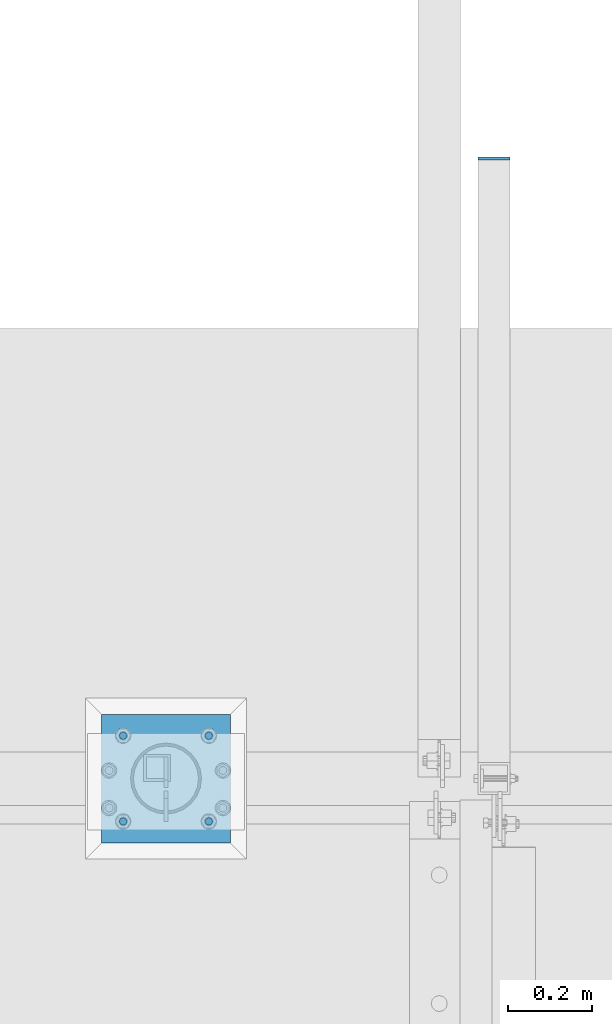
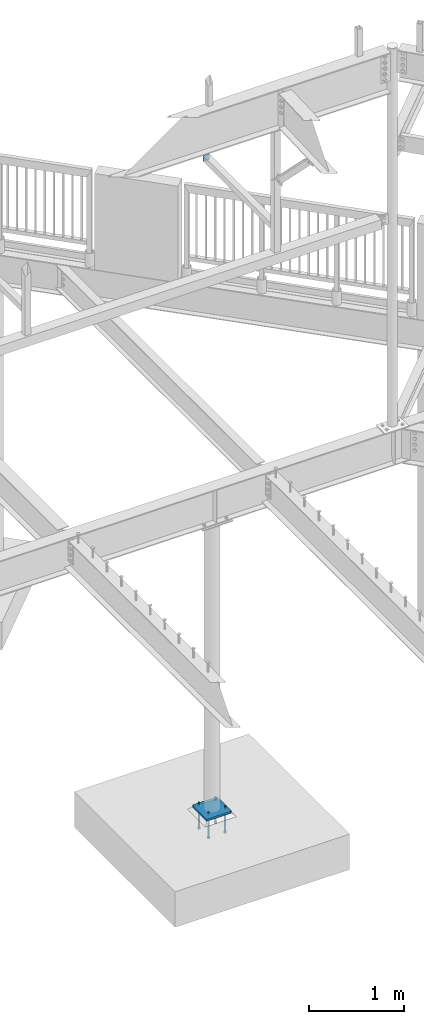
# One storey, part 447 of 975: 7 beams.
"""IFC2X3 building model written with IfcOpenShell, lengths in millimetres."""

from ifc_helpers import new_model, si_unit, frame, origin_with_axes, place, context, subcontext, project, spatial, faceted_brep, material, type_object, element, save


model = new_model("IFC2X3")

# Units and contexts
model_context = context("Model", 3, precision=1e-05, world=origin_with_axes())
body_context = subcontext(model_context, "Body", "Model", "MODEL_VIEW")
ifc_project = project(units=[si_unit("LENGTHUNIT", "METRE", prefix="MILLI"), si_unit("AREAUNIT", "SQUARE_METRE"), si_unit("VOLUMEUNIT", "CUBIC_METRE"), si_unit("MASSUNIT", "GRAM", prefix="KILO"), si_unit("TIMEUNIT", "SECOND"), si_unit("PLANEANGLEUNIT", "RADIAN"), si_unit("SOLIDANGLEUNIT", "STERADIAN"), si_unit("THERMODYNAMICTEMPERATUREUNIT", "DEGREE_CELSIUS"), si_unit("LUMINOUSINTENSITYUNIT", "LUMEN")], contexts=[model_context])

# Site, building, storey
site_placement = place(None, origin_with_axes())
site = spatial("IfcSite", under=ifc_project, at=site_placement, CompositionType="ELEMENT")
building_placement = place(site_placement, origin_with_axes())
building = spatial("IfcBuilding", under=site, at=building_placement, Name="Undefined", CompositionType="ELEMENT")
storey_placement = place(building_placement, origin_with_axes())
storey = spatial("IfcBuildingStorey", under=building, at=storey_placement, Name="Undefined", CompositionType="ELEMENT", Elevation=0.0)

# Beams
ifc_material_1 = material(Name="STEEL/A36")
beam_type_1 = type_object("IfcBeamType", PredefinedType="NOTDEFINED")
beam_1_placement = place(storey_placement, frame((23701.375, 22117.0499996575, 7035.8), z_axis=(1.0, 0.0, 0.0), x_axis=(0.0, 0.0, -1.0)))
element("IfcBeam", 1, at=beam_1_placement, inside=storey, type_object=beam_type_1, material=ifc_material_1, Name="PLATE", context=body_context, shape_type="Brep", body=[
    faceted_brep([(0.0, 3.17500000000018, -38.1000000000004), (0.0, 3.17500000000018, 38.1000000000004), (76.2000000000007, 3.17500000000018, 38.1000000000004), (76.2000000000007, 3.17500000000018, -38.1000000000004), (0.0, -3.17500000000018, 38.1000000000004), (76.2000000000007, -3.17500000000018, 38.1000000000004), (0.0, -3.17500000000018, -38.1000000000004), (76.2000000000007, -3.17500000000018, -38.1000000000004)], [[[0, 1, 2, 3]], [[1, 4, 5, 2]], [[4, 6, 7, 5]], [[6, 0, 3, 7]], [[5, 7, 3, 2]], [[6, 4, 1, 0]]]),
])
ifc_material_2 = material(Name="STEEL/F1554-36")
beam_type_2 = type_object("IfcBeamType", PredefinedType="NOTDEFINED")
beam_2_placement = place(storey_placement, frame((23025.0999984741, 20748.625, -304.799999999999), z_axis=(0.0, 1.0, 0.0), x_axis=(0.0, 0.0, -1.0)))
element("IfcBeam", 2, at=beam_2_placement, inside=storey, type_object=beam_type_2, material=ifc_material_2, Name="HEADED_ANCHOR_BOLT", context=body_context, shape_type="Brep", body=[
    faceted_brep([(209.543749999999, -9.13000011446275, 15.8100004196049), (209.543749999999, -18.2600002288382, 4.72937244921923e-11), (228.593749999998, -18.2600002288382, 4.72937244921923e-11), (228.593749999998, -9.13000011446275, 15.8100004196049), (209.543749999999, 9.13000011438271, 15.8100004195576), (228.593749999998, 9.13000011438271, 15.8100004195576), (209.543749999999, 18.2600002288382, -4.72937244921923e-11), (228.593749999998, 18.2600002288382, -4.72937244921923e-11), (209.543749999999, 9.13000011446275, -15.8100004196049), (228.593749999998, 9.13000011446275, -15.8100004196049), (209.543749999999, -9.13000011438271, -15.8100004195576), (228.593749999998, -9.13000011438271, -15.8100004195576), (209.543749999999, -4.4776800552936, 9.29799844178979), (209.543749999999, -8.068500660469, 6.43441456491473), (209.543749999999, -10.0612557561763, 2.2964159705416), (209.543749999999, -10.0612557561617, -2.29641597048976), (209.543749999999, -8.0685006604399, -6.4344145648729), (209.543749999999, -4.47768005524995, -9.29799844176705), (209.543749999999, 2.91038304567337e-11, -10.3199996948015), (209.543749999999, 4.4776800552936, -9.29799844178979), (209.543749999999, 8.068500660469, -6.43441456491473), (209.543749999999, 10.0612557561763, -2.2964159705416), (209.543749999999, 10.0612557561617, 2.29641597048976), (209.543749999999, 8.0685006604399, 6.4344145648729), (209.543749999999, 4.47768005524995, 9.29799844176705), (209.543749999999, -2.91038304567337e-11, 10.3199996948015), (228.593749999998, -2.91038304567337e-11, 10.3199996948015), (228.593749999998, -4.4776800552936, 9.29799844178979), (228.593749999998, -8.068500660469, 6.43441456491473), (228.593749999998, -10.0612557561763, 2.2964159705416), (228.593749999998, -10.0612557561617, -2.29641597048976), (228.593749999998, -8.0685006604399, -6.4344145648729), (228.593749999998, -4.47768005524995, -9.29799844176705), (228.593749999998, 2.91038304567337e-11, -10.3199996948015), (228.593749999998, 4.4776800552936, -9.29799844178979), (228.593749999998, 8.068500660469, -6.43441456491473), (228.593749999998, 10.0612557561763, -2.2964159705416), (228.593749999998, 10.0612557561617, 2.29641597048976), (228.593749999998, 8.0685006604399, 6.4344145648729), (228.593749999998, 4.47768005524995, 9.29799844176705), (0.0, -6.73519209080223, 6.73519209080186), (0.0, -9.52499999999964, 0.0), (228.6, -9.52500000000146, 0.0), (228.6, -6.73519209080405, 6.73519209080223), (-9.87109982941227e-13, -1.20792265079217e-13, 9.52499961853027), (228.6, 0.0, 9.52499999999964), (0.0, 6.73519209080223, 6.73519209080186), (228.6, 6.73519209080405, 6.73519209080223), (0.0, 9.52499999999964, 0.0), (228.6, 9.52500000000146, 0.0), (0.0, 6.73519209080223, -6.73519209080186), (228.6, 6.73519209080405, -6.73519209080223), (2.95075507493764e-12, -1.20792265079217e-13, -9.52499961853027), (228.6, 0.0, -9.52499999999964), (-114.297914995421, -6.36396103067818, 6.36396103068091), (-114.297914995421, -2.18278728425503e-11, 8.99999999997999), (-114.297914995421, 6.36396103064908, 6.36396103064817), (-114.297914995421, 8.99999999997817, -2.27373675443232e-11), (-114.297914995421, 6.36396103067818, -6.36396103068091), (-114.297914995421, 2.18278728425503e-11, -8.99999999997999), (-114.297914995421, -6.36396103064908, -6.36396103064817), (-114.297914995421, -8.99999999997817, 2.27373675443232e-11), (0.0149743263646087, 6.36396103067818, -6.36396103067909), (0.0149743263646087, 0.0, -9.0), (0.0149743263646087, -6.36396103067818, -6.36396103067909), (0.0149743263987148, -8.9999995411581, -1.00796984270346e-06), (0.0149743263646087, -6.36396103067818, 6.36396103067909), (0.0149743263646087, 0.0, 9.0), (0.0149743263646087, 6.36396103067818, 6.36396103067909), (0.0149743263987148, 9.0000004588419, -1.00796984270346e-06), (0.0, -6.73519209080223, -6.73519209080186), (228.6, -6.73519209080405, -6.73519209080223)], [[[0, 1, 2, 3]], [[4, 0, 3, 5]], [[6, 4, 5, 7]], [[8, 6, 7, 9]], [[10, 8, 9, 11]], [[0, 4, 6, 8, 10, 1], [12, 13, 14, 15, 16, 17, 18, 19, 20, 21, 22, 23, 24, 25]], [[12, 25, 26, 27]], [[13, 12, 27, 28]], [[14, 13, 28, 29]], [[15, 14, 29, 30]], [[16, 15, 30, 31]], [[17, 16, 31, 32]], [[18, 17, 32, 33]], [[19, 18, 33, 34]], [[20, 19, 34, 35]], [[21, 20, 35, 36]], [[22, 21, 36, 37]], [[23, 22, 37, 38]], [[24, 23, 38, 39]], [[25, 24, 39, 26]], [[9, 7, 5, 3, 2, 11], [38, 37, 36, 35, 34, 33, 32, 31, 30, 29, 28, 27, 26, 39]], [[1, 10, 11, 2]], [[40, 41, 42, 43]], [[44, 40, 43, 45]], [[46, 44, 45, 47]], [[48, 46, 47, 49]], [[50, 48, 49, 51]], [[52, 50, 51, 53]], [[54, 55, 56, 57, 58, 59, 60, 61]], [[59, 58, 62, 63]], [[60, 59, 63, 64]], [[61, 60, 64, 65]], [[54, 61, 65, 66]], [[55, 54, 66, 67]], [[56, 55, 67, 68]], [[57, 56, 68, 69]], [[58, 57, 69, 62]], [[40, 44, 46, 48, 50, 52, 70, 41], [68, 67, 66, 65, 64, 63, 62, 69]], [[41, 70, 71, 42]], [[53, 51, 49, 47, 45, 43, 42, 71]], [[70, 52, 53, 71]]]),
])
beam_3_placement = place(storey_placement, frame((22821.9139610307, 20748.6110389745, -304.799999999999), z_axis=(0.0, -1.0, 0.0), x_axis=(0.0, 0.0, -1.0)))
element("IfcBeam", 3, at=beam_3_placement, inside=storey, type_object=beam_type_2, material=ifc_material_2, Name="HEADED_ANCHOR_BOLT", context=body_context, shape_type="Brep", body=[
    faceted_brep([(209.543749999997, -9.14395961924311, 15.7960393889371), (209.543749999997, -18.273959733684, -0.0139610306796385), (228.593749999996, -18.273959733684, -0.0139610306796385), (228.593749999996, -9.14395961924311, 15.7960393889371), (209.543749999997, 9.11604060963873, 15.7960393889371), (228.593749999996, 9.11604060963873, 15.7960393889371), (209.543749999997, 18.2460407240796, -0.0139610306796385), (228.593749999996, 18.2460407240796, -0.0139610306796385), (209.543749999997, 9.11604060963873, -15.8239614502963), (228.593749999996, 9.11604060963873, -15.8239614502963), (209.543749999997, -9.14395961924311, -15.8239614502963), (228.593749999996, -9.14395961924311, -15.8239614502963), (209.543749999997, -4.49163956008488, 9.28403741111924), (209.543749999997, -8.08246016527482, 6.42045353422873), (209.543749999997, -10.075215260993, 2.28245493984195), (209.543749999997, -10.075215260993, -2.31037700120123), (209.543749999997, -8.08246016527482, -6.448375595588), (209.543749999997, -4.49163956008488, -9.31195947247852), (209.543749999997, -0.0139595048021874, -10.3339607255039), (209.543749999997, 4.4637205504805, -9.31195947247852), (209.543749999997, 8.05454115567045, -6.448375595588), (209.543749999997, 10.0472962513886, -2.31037700120123), (209.543749999997, 10.0472962513886, 2.28245493984195), (209.543749999997, 8.05454115567045, 6.42045353422873), (209.543749999997, 4.4637205504805, 9.28403741111924), (209.543749999997, -0.0139595048021874, 10.3060386641446), (228.593749999996, -0.0139595048021874, 10.3060386641446), (228.593749999996, -4.49163956008488, 9.28403741111924), (228.593749999996, -8.08246016527482, 6.42045353422873), (228.593749999996, -10.075215260993, 2.28245493984195), (228.593749999996, -10.075215260993, -2.31037700120123), (228.593749999996, -8.08246016527482, -6.448375595588), (228.593749999996, -4.49163956008488, -9.31195947247852), (228.593749999996, -0.0139595048021874, -10.3339607255039), (228.593749999996, 4.4637205504805, -9.31195947247852), (228.593749999996, 8.05454115567045, -6.448375595588), (228.593749999996, 10.0472962513886, -2.31037700120123), (228.593749999996, 10.0472962513886, 2.28245493984195), (228.593749999996, 8.05454115567045, 6.42045353422873), (228.593749999996, 4.4637205504805, 9.28403741111924), (0.0, -6.73519209080223, 6.73519209080186), (0.0, -9.52499999999964, 0.0), (228.6, -9.52500000000146, 0.0), (228.6, -6.73519209080405, 6.73519209080223), (-9.87109982941227e-13, -1.20792265079217e-13, 9.52499961853027), (228.6, 0.0, 9.52499999999964), (0.0, 6.73519209080223, 6.73519209080186), (228.6, 6.73519209080405, 6.73519209080223), (0.0, 9.52499999999964, 0.0), (228.6, 9.52500000000146, 0.0), (0.0, 6.73519209080223, -6.73519209080186), (228.6, 6.73519209080405, -6.73519209080223), (2.95075507493764e-12, -1.20792265079217e-13, -9.52499961853027), (228.6, 0.0, -9.52499999999964), (-114.299999999999, -6.37792053548037, 6.34999999999945), (-114.299999999999, -0.0139595048021874, 8.98603896932036), (-114.299999999999, 6.350001525876, 6.34999999999945), (-114.299999999999, 8.98604049519781, -0.0139610306796385), (-114.299999999999, 6.350001525876, -6.37792206135873), (-114.299999999999, -0.0139595048021874, -9.01396103067964), (-114.299999999999, -6.37792053548037, -6.37792206135873), (-114.299999999999, -9.01395950480219, -0.0139610306796385), (0.00625000636608775, 6.350001525876, -6.37792205092774), (0.00625000900208761, -0.0139595048021874, -9.01396102024955), (0.00625000636608775, -6.37792053548037, -6.37792205092774), (0.00625000000218279, -9.01395950480219, -0.0139610202495533), (0.00624999363827783, -6.37792053548037, 6.35000001042863), (0.00624999100227797, -0.0139595048021874, 8.98603897975045), (0.00624999363827783, 6.350001525876, 6.35000001042863), (0.00625000000218279, 8.98604049519781, -0.0139610202495533), (0.0, -6.73519209080223, -6.73519209080186), (228.6, -6.73519209080405, -6.73519209080223)], [[[0, 1, 2, 3]], [[4, 0, 3, 5]], [[6, 4, 5, 7]], [[8, 6, 7, 9]], [[10, 8, 9, 11]], [[0, 4, 6, 8, 10, 1], [12, 13, 14, 15, 16, 17, 18, 19, 20, 21, 22, 23, 24, 25]], [[12, 25, 26, 27]], [[13, 12, 27, 28]], [[14, 13, 28, 29]], [[15, 14, 29, 30]], [[16, 15, 30, 31]], [[17, 16, 31, 32]], [[18, 17, 32, 33]], [[19, 18, 33, 34]], [[20, 19, 34, 35]], [[21, 20, 35, 36]], [[22, 21, 36, 37]], [[23, 22, 37, 38]], [[24, 23, 38, 39]], [[25, 24, 39, 26]], [[9, 7, 5, 3, 2, 11], [38, 37, 36, 35, 34, 33, 32, 31, 30, 29, 28, 27, 26, 39]], [[1, 10, 11, 2]], [[40, 41, 42, 43]], [[44, 40, 43, 45]], [[46, 44, 45, 47]], [[48, 46, 47, 49]], [[50, 48, 49, 51]], [[52, 50, 51, 53]], [[54, 55, 56, 57, 58, 59, 60, 61]], [[59, 58, 62, 63]], [[60, 59, 63, 64]], [[61, 60, 64, 65]], [[54, 61, 65, 66]], [[55, 54, 66, 67]], [[56, 55, 67, 68]], [[57, 56, 68, 69]], [[58, 57, 69, 62]], [[40, 44, 46, 48, 50, 52, 70, 41], [68, 67, 66, 65, 64, 63, 62, 69]], [[41, 70, 71, 42]], [[53, 51, 49, 47, 45, 43, 42, 71]], [[70, 52, 53, 71]]]),
])
beam_4_placement = place(storey_placement, frame((22821.9000015259, 20545.4250030518, -304.799999999999), z_axis=(0.0, -1.0, 0.0), x_axis=(0.0, 0.0, -1.0)))
element("IfcBeam", 4, at=beam_4_placement, inside=storey, type_object=beam_type_2, material=ifc_material_2, Name="HEADED_ANCHOR_BOLT", context=body_context, shape_type="Brep", body=[
    faceted_brep([(209.543749999999, -9.13000011446275, 15.8100004196049), (209.543749999999, -18.2600002288382, 4.72937244921923e-11), (228.593749999998, -18.2600002288382, 4.72937244921923e-11), (228.593749999998, -9.13000011446275, 15.8100004196049), (209.543749999999, 9.13000011438271, 15.8100004195576), (228.593749999998, 9.13000011438271, 15.8100004195576), (209.543749999999, 18.2600002288382, -4.72937244921923e-11), (228.593749999998, 18.2600002288382, -4.72937244921923e-11), (209.543749999999, 9.13000011446275, -15.8100004196049), (228.593749999998, 9.13000011446275, -15.8100004196049), (209.543749999999, -9.13000011438271, -15.8100004195576), (228.593749999998, -9.13000011438271, -15.8100004195576), (209.543749999999, -4.4776800552936, 9.29799844178979), (209.543749999999, -8.068500660469, 6.43441456491473), (209.543749999999, -10.0612557561763, 2.2964159705416), (209.543749999999, -10.0612557561617, -2.29641597048976), (209.543749999999, -8.0685006604399, -6.4344145648729), (209.543749999999, -4.47768005524995, -9.29799844176705), (209.543749999999, 2.91038304567337e-11, -10.3199996948015), (209.543749999999, 4.4776800552936, -9.29799844178979), (209.543749999999, 8.068500660469, -6.43441456491473), (209.543749999999, 10.0612557561763, -2.2964159705416), (209.543749999999, 10.0612557561617, 2.29641597048976), (209.543749999999, 8.0685006604399, 6.4344145648729), (209.543749999999, 4.47768005524995, 9.29799844176705), (209.543749999999, -2.91038304567337e-11, 10.3199996948015), (228.593749999998, -2.91038304567337e-11, 10.3199996948015), (228.593749999998, -4.4776800552936, 9.29799844178979), (228.593749999998, -8.068500660469, 6.43441456491473), (228.593749999998, -10.0612557561763, 2.2964159705416), (228.593749999998, -10.0612557561617, -2.29641597048976), (228.593749999998, -8.0685006604399, -6.4344145648729), (228.593749999998, -4.47768005524995, -9.29799844176705), (228.593749999998, 2.91038304567337e-11, -10.3199996948015), (228.593749999998, 4.4776800552936, -9.29799844178979), (228.593749999998, 8.068500660469, -6.43441456491473), (228.593749999998, 10.0612557561763, -2.2964159705416), (228.593749999998, 10.0612557561617, 2.29641597048976), (228.593749999998, 8.0685006604399, 6.4344145648729), (228.593749999998, 4.47768005524995, 9.29799844176705), (0.0, -6.73519209080223, 6.73519209080186), (0.0, -9.52499999999964, 0.0), (228.6, -9.52500000000146, 0.0), (228.6, -6.73519209080405, 6.73519209080223), (-9.87109982941227e-13, -1.20792265079217e-13, 9.52499961853027), (228.6, 0.0, 9.52499999999964), (0.0, 6.73519209080223, 6.73519209080186), (228.6, 6.73519209080405, 6.73519209080223), (0.0, 9.52499999999964, 0.0), (228.6, 9.52500000000146, 0.0), (0.0, 6.73519209080223, -6.73519209080186), (228.6, 6.73519209080405, -6.73519209080223), (2.95075507493764e-12, -1.20792265079217e-13, -9.52499961853027), (228.6, 0.0, -9.52499999999964), (-114.297914995421, -6.36396103067818, 6.36396103068091), (-114.297914995421, -2.18278728425503e-11, 8.99999999997999), (-114.297914995421, 6.36396103064908, 6.36396103064817), (-114.297914995421, 8.99999999997817, -2.27373675443232e-11), (-114.297914995421, 6.36396103067818, -6.36396103068091), (-114.297914995421, 2.18278728425503e-11, -8.99999999997999), (-114.297914995421, -6.36396103064908, -6.36396103064817), (-114.297914995421, -8.99999999997817, 2.27373675443232e-11), (0.0149743263646087, 6.36396103067818, -6.36396103067909), (0.0149743263646087, 0.0, -9.0), (0.0149743263646087, -6.36396103067818, -6.36396103067909), (0.0149743263987148, -8.9999995411581, -1.00796984270346e-06), (0.0149743263646087, -6.36396103067818, 6.36396103067909), (0.0149743263646087, 0.0, 9.0), (0.0149743263646087, 6.36396103067818, 6.36396103067909), (0.0149743263987148, 9.0000004588419, -1.00796984270346e-06), (0.0, -6.73519209080223, -6.73519209080186), (228.6, -6.73519209080405, -6.73519209080223)], [[[0, 1, 2, 3]], [[4, 0, 3, 5]], [[6, 4, 5, 7]], [[8, 6, 7, 9]], [[10, 8, 9, 11]], [[0, 4, 6, 8, 10, 1], [12, 13, 14, 15, 16, 17, 18, 19, 20, 21, 22, 23, 24, 25]], [[12, 25, 26, 27]], [[13, 12, 27, 28]], [[14, 13, 28, 29]], [[15, 14, 29, 30]], [[16, 15, 30, 31]], [[17, 16, 31, 32]], [[18, 17, 32, 33]], [[19, 18, 33, 34]], [[20, 19, 34, 35]], [[21, 20, 35, 36]], [[22, 21, 36, 37]], [[23, 22, 37, 38]], [[24, 23, 38, 39]], [[25, 24, 39, 26]], [[9, 7, 5, 3, 2, 11], [38, 37, 36, 35, 34, 33, 32, 31, 30, 29, 28, 27, 26, 39]], [[1, 10, 11, 2]], [[40, 41, 42, 43]], [[44, 40, 43, 45]], [[46, 44, 45, 47]], [[48, 46, 47, 49]], [[50, 48, 49, 51]], [[52, 50, 51, 53]], [[54, 55, 56, 57, 58, 59, 60, 61]], [[59, 58, 62, 63]], [[60, 59, 63, 64]], [[61, 60, 64, 65]], [[54, 61, 65, 66]], [[55, 54, 66, 67]], [[56, 55, 67, 68]], [[57, 56, 68, 69]], [[58, 57, 69, 62]], [[40, 44, 46, 48, 50, 52, 70, 41], [68, 67, 66, 65, 64, 63, 62, 69]], [[41, 70, 71, 42]], [[53, 51, 49, 47, 45, 43, 42, 71]], [[70, 52, 53, 71]]]),
])
beam_5_placement = place(storey_placement, frame((23025.0999984741, 20545.4250030518, -304.799999999999), z_axis=(0.0, 1.0, 0.0), x_axis=(0.0, 0.0, -1.0)))
element("IfcBeam", 5, at=beam_5_placement, inside=storey, type_object=beam_type_2, material=ifc_material_2, Name="HEADED_ANCHOR_BOLT", context=body_context, shape_type="Brep", body=[
    faceted_brep([(209.543749999999, -9.13000011446275, 15.8100004196049), (209.543749999999, -18.2600002288382, 4.72937244921923e-11), (228.593749999998, -18.2600002288382, 4.72937244921923e-11), (228.593749999998, -9.13000011446275, 15.8100004196049), (209.543749999999, 9.13000011438271, 15.8100004195576), (228.593749999998, 9.13000011438271, 15.8100004195576), (209.543749999999, 18.2600002288382, -4.72937244921923e-11), (228.593749999998, 18.2600002288382, -4.72937244921923e-11), (209.543749999999, 9.13000011446275, -15.8100004196049), (228.593749999998, 9.13000011446275, -15.8100004196049), (209.543749999999, -9.13000011438271, -15.8100004195576), (228.593749999998, -9.13000011438271, -15.8100004195576), (209.543749999999, -4.4776800552936, 9.29799844178979), (209.543749999999, -8.068500660469, 6.43441456491473), (209.543749999999, -10.0612557561763, 2.2964159705416), (209.543749999999, -10.0612557561617, -2.29641597048976), (209.543749999999, -8.0685006604399, -6.4344145648729), (209.543749999999, -4.47768005524995, -9.29799844176705), (209.543749999999, 2.91038304567337e-11, -10.3199996948015), (209.543749999999, 4.4776800552936, -9.29799844178979), (209.543749999999, 8.068500660469, -6.43441456491473), (209.543749999999, 10.0612557561763, -2.2964159705416), (209.543749999999, 10.0612557561617, 2.29641597048976), (209.543749999999, 8.0685006604399, 6.4344145648729), (209.543749999999, 4.47768005524995, 9.29799844176705), (209.543749999999, -2.91038304567337e-11, 10.3199996948015), (228.593749999998, -2.91038304567337e-11, 10.3199996948015), (228.593749999998, -4.4776800552936, 9.29799844178979), (228.593749999998, -8.068500660469, 6.43441456491473), (228.593749999998, -10.0612557561763, 2.2964159705416), (228.593749999998, -10.0612557561617, -2.29641597048976), (228.593749999998, -8.0685006604399, -6.4344145648729), (228.593749999998, -4.47768005524995, -9.29799844176705), (228.593749999998, 2.91038304567337e-11, -10.3199996948015), (228.593749999998, 4.4776800552936, -9.29799844178979), (228.593749999998, 8.068500660469, -6.43441456491473), (228.593749999998, 10.0612557561763, -2.2964159705416), (228.593749999998, 10.0612557561617, 2.29641597048976), (228.593749999998, 8.0685006604399, 6.4344145648729), (228.593749999998, 4.47768005524995, 9.29799844176705), (0.0, -6.73519209080223, 6.73519209080186), (0.0, -9.52499999999964, 0.0), (228.6, -9.52500000000146, 0.0), (228.6, -6.73519209080405, 6.73519209080223), (-9.87109982941227e-13, -1.20792265079217e-13, 9.52499961853027), (228.6, 0.0, 9.52499999999964), (0.0, 6.73519209080223, 6.73519209080186), (228.6, 6.73519209080405, 6.73519209080223), (0.0, 9.52499999999964, 0.0), (228.6, 9.52500000000146, 0.0), (0.0, 6.73519209080223, -6.73519209080186), (228.6, 6.73519209080405, -6.73519209080223), (2.95075507493764e-12, -1.20792265079217e-13, -9.52499961853027), (228.6, 0.0, -9.52499999999964), (-114.297914995421, -6.36396103067818, 6.36396103068091), (-114.297914995421, -2.18278728425503e-11, 8.99999999997999), (-114.297914995421, 6.36396103064908, 6.36396103064817), (-114.297914995421, 8.99999999997817, -2.27373675443232e-11), (-114.297914995421, 6.36396103067818, -6.36396103068091), (-114.297914995421, 2.18278728425503e-11, -8.99999999997999), (-114.297914995421, -6.36396103064908, -6.36396103064817), (-114.297914995421, -8.99999999997817, 2.27373675443232e-11), (0.0149743263646087, 6.36396103067818, -6.36396103067909), (0.0149743263646087, 0.0, -9.0), (0.0149743263646087, -6.36396103067818, -6.36396103067909), (0.0149743263987148, -8.9999995411581, -1.00796984270346e-06), (0.0149743263646087, -6.36396103067818, 6.36396103067909), (0.0149743263646087, 0.0, 9.0), (0.0149743263646087, 6.36396103067818, 6.36396103067909), (0.0149743263987148, 9.0000004588419, -1.00796984270346e-06), (0.0, -6.73519209080223, -6.73519209080186), (228.6, -6.73519209080405, -6.73519209080223)], [[[0, 1, 2, 3]], [[4, 0, 3, 5]], [[6, 4, 5, 7]], [[8, 6, 7, 9]], [[10, 8, 9, 11]], [[0, 4, 6, 8, 10, 1], [12, 13, 14, 15, 16, 17, 18, 19, 20, 21, 22, 23, 24, 25]], [[12, 25, 26, 27]], [[13, 12, 27, 28]], [[14, 13, 28, 29]], [[15, 14, 29, 30]], [[16, 15, 30, 31]], [[17, 16, 31, 32]], [[18, 17, 32, 33]], [[19, 18, 33, 34]], [[20, 19, 34, 35]], [[21, 20, 35, 36]], [[22, 21, 36, 37]], [[23, 22, 37, 38]], [[24, 23, 38, 39]], [[25, 24, 39, 26]], [[9, 7, 5, 3, 2, 11], [38, 37, 36, 35, 34, 33, 32, 31, 30, 29, 28, 27, 26, 39]], [[1, 10, 11, 2]], [[40, 41, 42, 43]], [[44, 40, 43, 45]], [[46, 44, 45, 47]], [[48, 46, 47, 49]], [[50, 48, 49, 51]], [[52, 50, 51, 53]], [[54, 55, 56, 57, 58, 59, 60, 61]], [[59, 58, 62, 63]], [[60, 59, 63, 64]], [[61, 60, 64, 65]], [[54, 61, 65, 66]], [[55, 54, 66, 67]], [[56, 55, 67, 68]], [[57, 56, 68, 69]], [[58, 57, 69, 62]], [[40, 44, 46, 48, 50, 52, 70, 41], [68, 67, 66, 65, 64, 63, 62, 69]], [[41, 70, 71, 42]], [[53, 51, 49, 47, 45, 43, 42, 71]], [[70, 52, 53, 71]]]),
])
beam_type_3 = type_object("IfcBeamType", PredefinedType="NOTDEFINED")
beam_6_placement = place(storey_placement, frame((22923.5, 20494.625, -265.112500000001), z_axis=(-0.999999999999998, 6.90000001668524e-08, 0.0), x_axis=(0.0, 1.0, 0.0)))
element("IfcBeam", 6, at=beam_6_placement, inside=storey, type_object=beam_type_3, material=ifc_material_1, Name="TEMPLATE", context=body_context, shape_type="Brep", body=[
    faceted_brep([(0.0, 1.58750000000009, -152.4), (0.0, 1.58750000000009, 152.4), (304.799999999153, 1.58750000000001, 152.400000000001), (304.799999999153, 1.58750000000001, -152.400000000001), (0.0, -1.58750000000009, 152.4), (304.799999999153, -1.58750000000001, 152.400000000001), (0.0, -1.58750000000009, -152.4), (304.799999999153, -1.58750000000001, -152.400000000001)], [[[0, 1, 2, 3]], [[1, 4, 5, 2]], [[4, 6, 7, 5]], [[6, 0, 3, 7]], [[5, 7, 3, 2]], [[6, 4, 1, 0]]]),
])
beam_type_4 = type_object("IfcBeamType", PredefinedType="NOTDEFINED")
beam_7_placement = place(storey_placement, frame((22923.5, 20494.625, -254.0), z_axis=(-0.999999999999998, 6.90000001668524e-08, 0.0), x_axis=(0.0, 1.0, 0.0)))
element("IfcBeam", 7, at=beam_7_placement, inside=storey, type_object=beam_type_4, material=ifc_material_1, Name="PLATE", context=body_context, shape_type="Brep", body=[
    faceted_brep([(0.0, 12.7, -152.400000000001), (-1.36424205265939e-12, 12.7, 152.400009155273), (304.800000000003, 12.7, 152.400000000001), (304.800000000003, 12.7, -152.400000000001), (0.0, -12.7, 152.400000000001), (304.800000000003, -12.7, 152.400000000001), (0.0, -12.7, -152.400000000001), (304.800000000003, -12.7, -152.400000000001)], [[[0, 1, 2, 3]], [[1, 4, 5, 2]], [[4, 6, 7, 5]], [[6, 0, 3, 7]], [[5, 7, 3, 2]], [[6, 4, 1, 0]]]),
])

save(model, "model.ifc")
